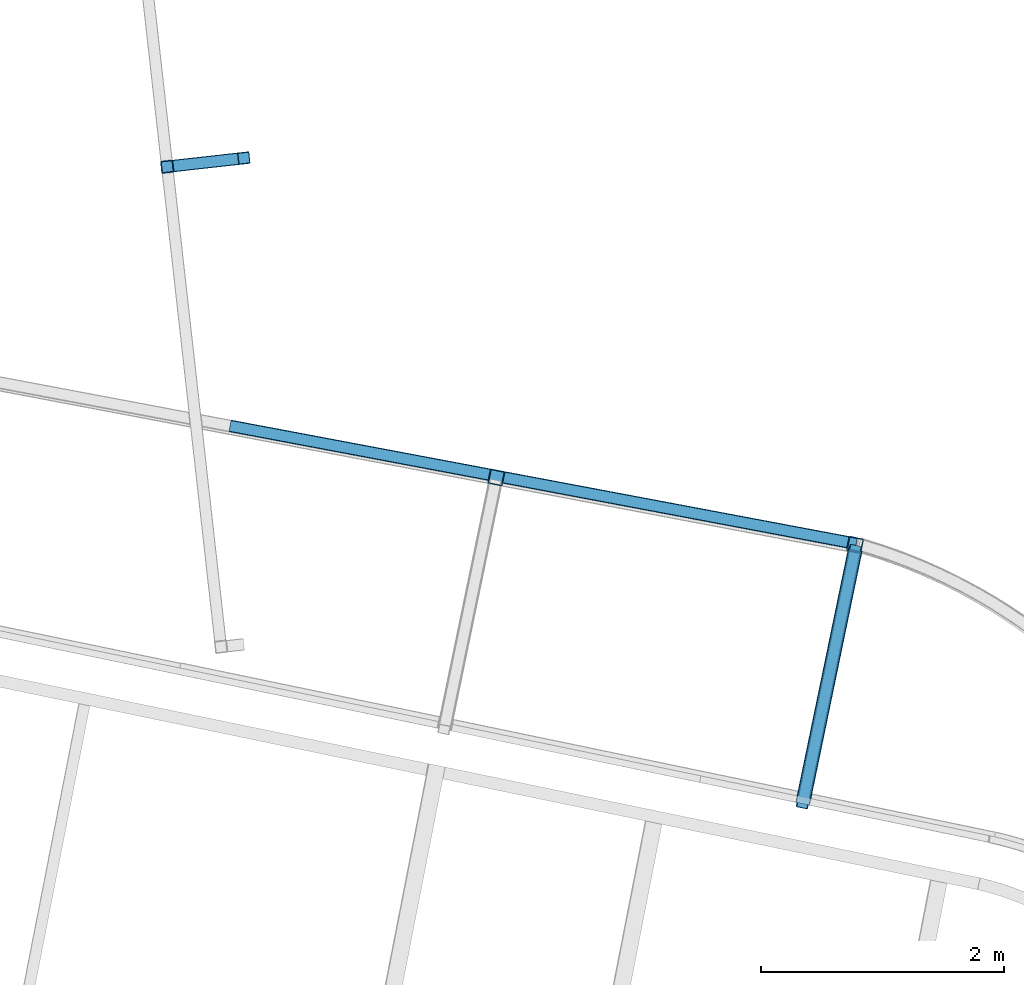
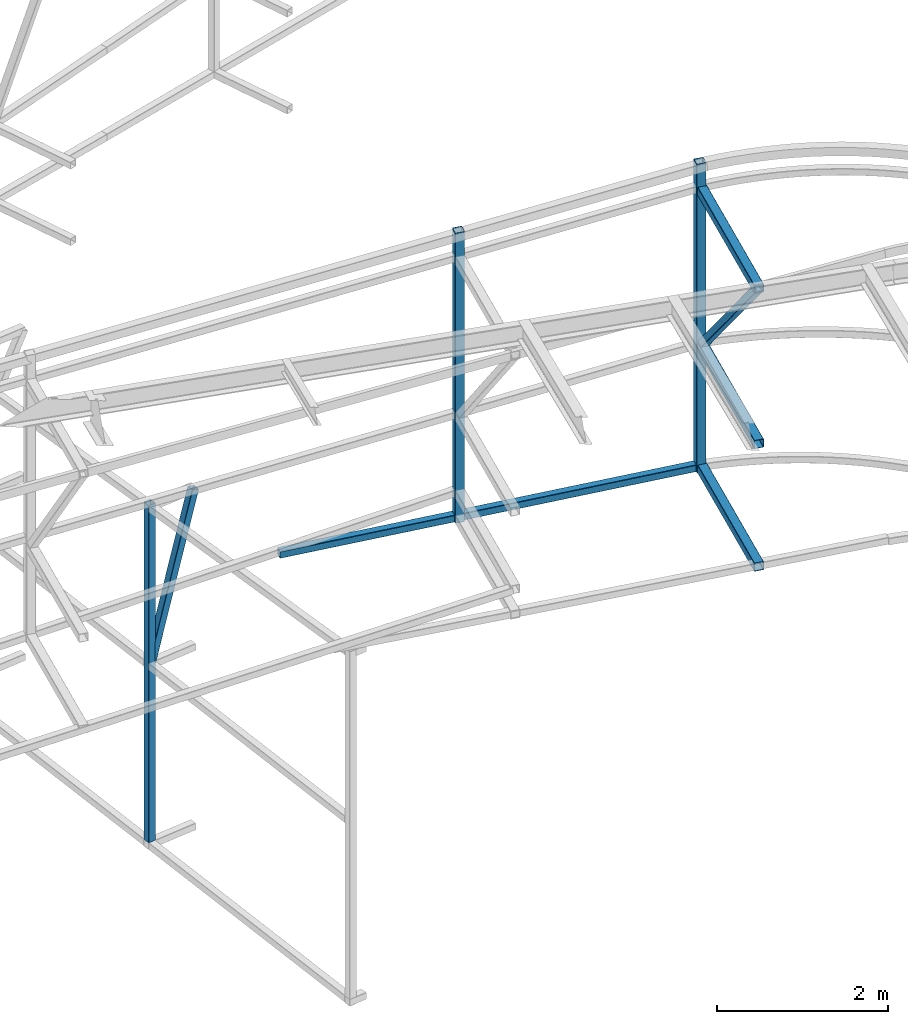
# One storey, part 101 of 215: 7 beams, 2 members, 9 elements without a shape of their own.
"""IFC2X3 building model written with IfcOpenShell, lengths in millimetres."""

from ifc_helpers import new_model, si_unit, frame, origin_with_axes, origin_2d_with_axis, place, context, subcontext, project, spatial, hollow_rectangle, extrude, material, type_object, element, aggregate, save


model = new_model("IFC2X3")

# Units and contexts
model_context = context("Model", 3, precision=1e-05, world=origin_with_axes())
body_context = subcontext(model_context, "Body", "Model", "MODEL_VIEW")
ifc_project = project(units=[si_unit("LENGTHUNIT", "METRE", prefix="MILLI"), si_unit("AREAUNIT", "SQUARE_METRE"), si_unit("VOLUMEUNIT", "CUBIC_METRE"), si_unit("MASSUNIT", "GRAM", prefix="KILO"), si_unit("TIMEUNIT", "SECOND"), si_unit("PLANEANGLEUNIT", "RADIAN"), si_unit("SOLIDANGLEUNIT", "STERADIAN"), si_unit("THERMODYNAMICTEMPERATUREUNIT", "DEGREE_CELSIUS"), si_unit("LUMINOUSINTENSITYUNIT", "LUMEN")], contexts=[model_context])

# Site, building, storey
site_placement = place(None, origin_with_axes())
site = spatial("IfcSite", under=ifc_project, at=site_placement, CompositionType="ELEMENT")
building_placement = place(site_placement, origin_with_axes())
building = spatial("IfcBuilding", under=site, at=building_placement, Name="Undefined", CompositionType="ELEMENT")
storey_placement = place(building_placement, origin_with_axes())
storey = spatial("IfcBuildingStorey", under=building, at=storey_placement, Name="Undefined", CompositionType="ELEMENT", Elevation=0.0)

# Assembly, beam
assembly_1_placement = place(storey_placement, origin_with_axes())
assembly_1 = element("IfcElementAssembly", 1, at=assembly_1_placement, inside=storey, Name="Steel Assembly", AssemblyPlace="NOTDEFINED", PredefinedType="RIGID_FRAME")
ifc_material = material(Name="STEEL/S275JR")
beam_type_1 = type_object("IfcBeamType", PredefinedType="NOTDEFINED")
beam_1_placement = place(assembly_1_placement, frame((92493.8715568127, 60640.7809693087, 7490.39698056694), z_axis=(-0.111238280970791, 0.993793763739068, 0.0), x_axis=(0.0, 0.0, -1.0)))
beam_1 = element("IfcBeam", 2, at=beam_1_placement, type_object=beam_type_1, material=ifc_material, Name="LISSE", context=body_context, shape_type="SweptSolid", body=[
    extrude(hollow_rectangle(XDim=100.0, YDim=100.0, WallThickness=4.0, InnerFilletRadius=4.0, OuterFilletRadius=8.0, at=origin_2d_with_axis()), frame((4820.39732403525, 0.0, 0.0), z_axis=(-1.0, 0.0, 0.0), x_axis=(-6.93889390390723e-18, -1.0, -3.46944695195361e-18)), (0.0, 0.0, 1.0), 4820.4),
])
aggregate(assembly_1, [beam_1])

# Assembly, member
assembly_2_placement = place(storey_placement, origin_with_axes())
assembly_2 = element("IfcElementAssembly", 3, at=assembly_2_placement, inside=storey, Name="Steel Assembly", AssemblyPlace="NOTDEFINED", PredefinedType="RIGID_FRAME")
member_type_1 = type_object("IfcMemberType", PredefinedType="NOTDEFINED")
member_1_placement = place(assembly_2_placement, frame((93124.0754363296, 60711.3213346973, 7441.16589599155), z_axis=(-0.111241487973639, 0.993793404764497, 0.0), x_axis=(-0.268963730938331, -0.0301067889930969, -0.962679641779267)))
member_1 = element("IfcMember", 4, at=member_1_placement, type_object=member_type_1, material=ifc_material, Name="LISSE", context=body_context, shape_type="SweptSolid", body=[
    extrude(hollow_rectangle(XDim=100.0, YDim=100.0, WallThickness=4.0, InnerFilletRadius=4.0, OuterFilletRadius=8.0, at=origin_2d_with_axis()), frame((2342.62561340662, 1.46819570730709e-11, 7.28760614913335e-12), z_axis=(-1.0, 0.0, 0.0), x_axis=(-6.93889390390723e-18, -1.0, -3.46944695195361e-18)), (0.0, 0.0, 1.0), 2342.6),
])
aggregate(assembly_2, [member_1])

# Assembly, beam
assembly_3_placement = place(storey_placement, origin_with_axes())
assembly_3 = element("IfcElementAssembly", 5, at=assembly_3_placement, inside=storey, Name="Steel Assembly", AssemblyPlace="NOTDEFINED", PredefinedType="RIGID_FRAME")
beam_type_2 = type_object("IfcBeamType", PredefinedType="NOTDEFINED")
beam_2_placement = place(assembly_3_placement, frame((95197.6392567204, 58088.7354967303, 11992.7528167807), z_axis=(-0.202748471950327, -0.979230849760059, 0.0), x_axis=(0.0, 0.0, -1.0)))
beam_2 = element("IfcBeam", 6, at=beam_2_placement, type_object=beam_type_2, material=ifc_material, Name="MONTANT", context=body_context, shape_type="SweptSolid", body=[
    extrude(hollow_rectangle(XDim=120.0, YDim=120.0, WallThickness=5.0, InnerFilletRadius=5.0, OuterFilletRadius=10.0, at=origin_2d_with_axis()), frame((4148.27741698863, 0.0, 0.0), z_axis=(-1.0, 0.0, 0.0), x_axis=(-6.93889390390723e-18, -1.0, -3.46944695195361e-18)), (0.0, 0.0, 1.0), 4148.3),
])
aggregate(assembly_3, [beam_2])

assembly_4_placement = place(storey_placement, origin_with_axes())
assembly_4 = element("IfcElementAssembly", 7, at=assembly_4_placement, inside=storey, Name="Steel Assembly", AssemblyPlace="NOTDEFINED", PredefinedType="RIGID_FRAME")
beam_3_placement = place(assembly_4_placement, frame((98144.1315763509, 57535.2327810723, 12282.6005199519), z_axis=(-0.201709649036001, -0.979445362174825, -1.00000033871425e-09), x_axis=(0.0, 0.0, -1.0)))
beam_3 = element("IfcBeam", 8, at=beam_3_placement, type_object=beam_type_2, material=ifc_material, Name="MONTANT", context=body_context, shape_type="SweptSolid", body=[
    extrude(hollow_rectangle(XDim=120.0, YDim=120.0, WallThickness=5.0, InnerFilletRadius=5.0, OuterFilletRadius=10.0, at=origin_2d_with_axis()), frame((4411.24039432513, 0.0, 0.0), z_axis=(-1.0, 0.0, 0.0), x_axis=(-6.93889390390723e-18, -1.0, -3.46944695195361e-18)), (0.0, 0.0, 1.0), 4411.2),
])
aggregate(assembly_4, [beam_3])

assembly_5_placement = place(storey_placement, origin_with_axes())
assembly_5 = element("IfcElementAssembly", 9, at=assembly_5_placement, inside=storey, Name="Steel Assembly", AssemblyPlace="NOTDEFINED", PredefinedType="RIGID_FRAME")
beam_4_placement = place(assembly_5_placement, frame((98144.9246685471, 57489.5140406278, 7921.36843875735), z_axis=(-0.979231775367019, 0.202741665075991, -0.000973321000365208), x_axis=(-0.202741743916484, -0.979232242596629, -1.82449999926897e-05)))
beam_4 = element("IfcBeam", 10, at=beam_4_placement, type_object=beam_type_2, material=ifc_material, context=body_context, shape_type="SweptSolid", body=[
    extrude(hollow_rectangle(XDim=120.0, YDim=120.0, WallThickness=5.0, InnerFilletRadius=5.0, OuterFilletRadius=10.0, at=origin_2d_with_axis()), frame((2126.2304690465, -3.60197452147667e-17, 1.45296264351514e-11), z_axis=(-1.0, 0.0, 0.0), x_axis=(-6.93889390390723e-18, -1.0, -3.46944695195361e-18)), (0.0, 0.0, 1.0), 2126.2),
])
aggregate(assembly_5, [beam_4])

assembly_6_placement = place(storey_placement, origin_with_axes())
assembly_6 = element("IfcElementAssembly", 11, at=assembly_6_placement, inside=storey, Name="Steel Assembly", AssemblyPlace="NOTDEFINED", PredefinedType="RIGID_FRAME")
beam_5_placement = place(assembly_6_placement, frame((98145.8576410376, 57494.0378693748, 9674.88139211412), z_axis=(-0.979232115329423, 0.202740023068201, -0.000973321000326915), x_axis=(-0.202740101908838, -0.979232582559698, -1.8205999991694e-05)))
beam_5 = element("IfcBeam", 12, at=beam_5_placement, type_object=beam_type_2, material=ifc_material, context=body_context, shape_type="SweptSolid", body=[
    extrude(hollow_rectangle(XDim=120.0, YDim=120.0, WallThickness=5.0, InnerFilletRadius=5.0, OuterFilletRadius=10.0, at=origin_2d_with_axis()), frame((2130.8495007619, -1.44391978622857e-17, -7.35004805932992e-14), z_axis=(-1.0, 0.0, 0.0), x_axis=(-6.93889390390723e-18, -1.0, -3.46944695195361e-18)), (0.0, 0.0, 1.0), 2130.8),
])
aggregate(assembly_6, [beam_5])

assembly_7_placement = place(storey_placement, origin_with_axes())
assembly_7 = element("IfcElementAssembly", 13, at=assembly_7_placement, inside=storey, Name="Steel Assembly", AssemblyPlace="NOTDEFINED", PredefinedType="RIGID_FRAME")
beam_6_placement = place(assembly_7_placement, frame((98145.8669268858, 57494.0304034318, 11893.2847389768), z_axis=(-0.979232676907323, 0.202739569980809, -0.000176750999984147), x_axis=(-0.202739587989615, -0.979232684949846, 9.04859999952229e-05)))
beam_6 = element("IfcBeam", 14, at=beam_6_placement, type_object=beam_type_2, material=ifc_material, context=body_context, shape_type="SweptSolid", body=[
    extrude(hollow_rectangle(XDim=120.0, YDim=120.0, WallThickness=5.0, InnerFilletRadius=5.0, OuterFilletRadius=10.0, at=origin_2d_with_axis()), frame((2130.8643086281, -1.81901828214227e-12, -1.45684932841637e-11), z_axis=(-1.0, 0.0, 0.0), x_axis=(-6.93889390390723e-18, -1.0, -3.46944695195361e-18)), (0.0, 0.0, 1.0), 2130.9),
])
aggregate(assembly_7, [beam_6])

assembly_8_placement = place(storey_placement, origin_with_axes())
assembly_8 = element("IfcElementAssembly", 15, at=assembly_8_placement, inside=storey, Name="Steel Assembly", AssemblyPlace="NOTDEFINED", PredefinedType="RIGID_FRAME")
beam_type_3 = type_object("IfcBeamType", PredefinedType="NOTDEFINED")
beam_7_placement = place(assembly_8_placement, frame((93010.6626349753, 58511.8353411678, 7879.6155139754), z_axis=(0.185059002917875, 0.982727411563879, 0.0), x_axis=(0.982694948401379, -0.185052888075584, 0.00812816100331988)))
beam_7 = element("IfcBeam", 16, at=beam_7_placement, type_object=beam_type_3, material=ifc_material, Name="LISSE", context=body_context, shape_type="SweptSolid", body=[
    extrude(hollow_rectangle(XDim=100.0, YDim=100.0, WallThickness=5.0, InnerFilletRadius=5.0, OuterFilletRadius=10.0, at=origin_2d_with_axis()), frame((5234.47893680718, 9.08037349618556e-15, -1.44323246905762e-11), z_axis=(-1.0, 0.0, 0.0), x_axis=(-6.93889390390723e-18, -1.0, -3.46944695195361e-18)), (0.0, 0.0, 1.0), 5234.5),
])
aggregate(assembly_8, [beam_7])

# Assembly, member
assembly_9_placement = place(storey_placement, origin_with_axes())
assembly_9 = element("IfcElementAssembly", 17, at=assembly_9_placement, inside=storey, Name="Steel Assembly", AssemblyPlace="NOTDEFINED", PredefinedType="RIGID_FRAME")
member_type_2 = type_object("IfcMemberType", PredefinedType="NOTDEFINED")
member_2_placement = place(assembly_9_placement, frame((97713.8463702197, 55407.4224353595, 11913.4846220481), z_axis=(-0.979331209983243, 0.202262616996539, -0.000463592999992467), x_axis=(0.139780079986269, 0.67513811293368, -0.724327313928849)))
member_2 = element("IfcMember", 18, at=member_2_placement, type_object=member_type_2, material=ifc_material, context=body_context, shape_type="SweptSolid", body=[
    extrude(hollow_rectangle(XDim=100.0, YDim=100.0, WallThickness=5.0, InnerFilletRadius=5.0, OuterFilletRadius=10.0, at=origin_2d_with_axis()), frame((3090.64973842372, 3.43131050064973e-13, -6.40019829711034e-14), z_axis=(-1.0, 0.0, 0.0), x_axis=(-6.93889390390723e-18, -1.0, -3.46944695195361e-18)), (0.0, 0.0, 1.0), 3090.6),
])
aggregate(assembly_9, [member_2])

save(model, "model.ifc")
